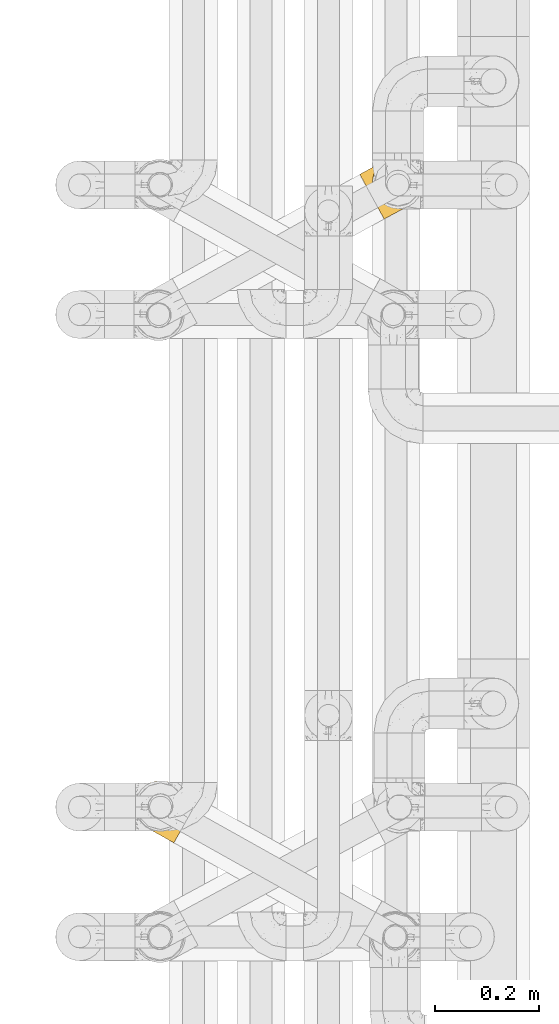
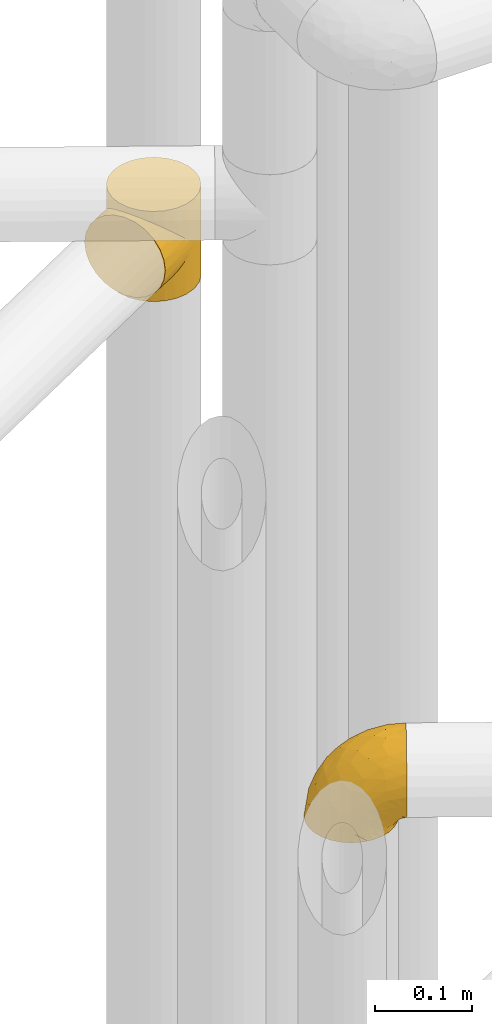
# One storey, part 167 of 827: 2 coverings.
"""IFC2X3 building model written with IfcOpenShell, lengths in millimetres."""

from ifc_helpers import new_model, entity, si_unit, converted_unit, derived_unit, direction, frame, origin, place, context, subcontext, project, spatial, faceted_brep, element, save


model = new_model("IFC2X3")

# Units and contexts
model_context = context("Model", 3, precision=0.01, world=origin(), true_north=direction((6.12303176911189e-17, 1.0)))
body_context = subcontext(model_context, "Body", "Model", "MODEL_VIEW")
ifc_project = project(units=[si_unit("LENGTHUNIT", "METRE", prefix="MILLI"), si_unit("AREAUNIT", "SQUARE_METRE"), si_unit("VOLUMEUNIT", "CUBIC_METRE"), converted_unit("PLANEANGLEUNIT", "DEGREE", entity("IfcRatioMeasure", 0.0174532925199433), si_unit("PLANEANGLEUNIT", "RADIAN"), dimensions=[0, 0, 0, 0, 0, 0, 0]), si_unit("MASSUNIT", "GRAM", prefix="KILO"), derived_unit("MASSDENSITYUNIT", [(si_unit("MASSUNIT", "GRAM", prefix="KILO"), 1), (si_unit("LENGTHUNIT", "METRE"), -3)]), derived_unit("MOMENTOFINERTIAUNIT", [(si_unit("LENGTHUNIT", "METRE"), 4)]), si_unit("TIMEUNIT", "SECOND"), si_unit("FREQUENCYUNIT", "HERTZ"), si_unit("THERMODYNAMICTEMPERATUREUNIT", "DEGREE_CELSIUS"), derived_unit("THERMALTRANSMITTANCEUNIT", [(si_unit("MASSUNIT", "GRAM", prefix="KILO"), 1), (si_unit("THERMODYNAMICTEMPERATUREUNIT", "KELVIN"), -1), (si_unit("TIMEUNIT", "SECOND"), -3)]), derived_unit("VOLUMETRICFLOWRATEUNIT", [(si_unit("LENGTHUNIT", "METRE"), 3), (si_unit("TIMEUNIT", "SECOND"), -1)]), derived_unit("MASSFLOWRATEUNIT", [(si_unit("MASSUNIT", "GRAM", prefix="KILO"), 1), (si_unit("TIMEUNIT", "SECOND"), -1)]), derived_unit("ROTATIONALFREQUENCYUNIT", [(si_unit("TIMEUNIT", "SECOND"), -1)]), si_unit("ELECTRICCURRENTUNIT", "AMPERE"), si_unit("ELECTRICVOLTAGEUNIT", "VOLT"), si_unit("POWERUNIT", "WATT"), si_unit("FORCEUNIT", "NEWTON", prefix="KILO"), si_unit("ILLUMINANCEUNIT", "LUX"), si_unit("LUMINOUSFLUXUNIT", "LUMEN"), si_unit("LUMINOUSINTENSITYUNIT", "CANDELA"), derived_unit("USERDEFINED", [(si_unit("MASSUNIT", "GRAM", prefix="KILO"), -1), (si_unit("LENGTHUNIT", "METRE"), -2), (si_unit("TIMEUNIT", "SECOND"), 3), (si_unit("LUMINOUSFLUXUNIT", "LUMEN"), 1)]), derived_unit("LINEARVELOCITYUNIT", [(si_unit("LENGTHUNIT", "METRE"), 1), (si_unit("TIMEUNIT", "SECOND"), -1)]), si_unit("PRESSUREUNIT", "PASCAL"), derived_unit("USERDEFINED", [(si_unit("LENGTHUNIT", "METRE"), -2), (si_unit("MASSUNIT", "GRAM", prefix="KILO"), 1), (si_unit("TIMEUNIT", "SECOND"), -2)]), derived_unit("LINEARFORCEUNIT", [(si_unit("MASSUNIT", "GRAM", prefix="KILO"), 1), (si_unit("LENGTHUNIT", "METRE"), 1), (si_unit("TIMEUNIT", "SECOND"), -2), (si_unit("LENGTHUNIT", "METRE"), -1)]), derived_unit("PLANARFORCEUNIT", [(si_unit("MASSUNIT", "GRAM", prefix="KILO"), 1), (si_unit("LENGTHUNIT", "METRE"), 1), (si_unit("TIMEUNIT", "SECOND"), -2), (si_unit("LENGTHUNIT", "METRE"), -2)])], contexts=[model_context])

# Site, building, storey
site_placement = place(None, origin())
site = spatial("IfcSite", under=ifc_project, at=site_placement, CompositionType="ELEMENT")
building_placement = place(site_placement, origin())
building = spatial("IfcBuilding", under=site, at=building_placement, CompositionType="ELEMENT")
storey_placement = place(building_placement, frame((0.0, 0.0, 28200.0)))
storey = spatial("IfcBuildingStorey", under=building, at=storey_placement, Name="08", CompositionType="ELEMENT", Elevation=28200.0)

# Coverings
covering_1_placement = place(storey_placement, frame((35659.02, 12938.72, 2043.0)))
element("IfcCovering", 1, at=covering_1_placement, inside=storey, Name=":ADSK_", ObjectType=":ADSK_", PredefinedType="INSULATION", context=body_context, shape_type="Brep", body=[
    faceted_brep([(46.11, 111.63, 50.38), (51.72, 115.18, 0.0), (41.33, 107.65, 0.0), (33.24, 97.68, 0.0), (36.42, 102.26, 37.4), (29.35, 89.87, 25.28), (28.01, 85.97, 0.0), (32.5, 96.44, 31.18), (51.72, 115.18, 57.0), (46.11, 111.63, 63.62), (51.72, 115.18, 114.0), (30.08, 52.85, 8.29), (29.61, 54.55, 0.0), (30.76, 51.55, 0.0), (40.99, 107.32, 43.83), (31.9, 48.55, 7.85), (31.9, 48.55, 0.0), (30.76, 51.55, 114.0), (31.9, 48.55, 106.15), (31.9, 48.55, 114.0), (27.13, 82.55, 19.84), (25.99, 73.3, 0.0), (26.65, 66.92, 0.0), (27.32, 60.54, 0.0), (27.3, 61.56, 10.0), (28.26, 57.15, 8.74), (26.04, 74.54, 15.07), (26.34, 65.98, 11.25), (28.46, 57.54, 0.0), (33.78, 45.96, 0.0), (35.67, 43.36, 0.0), (34.83, 44.29, 8.4), (37.76, 40.02, 8.94), (37.55, 40.76, 0.0), (39.43, 38.16, 0.0), (44.97, 33.14, 12.0), (44.41, 34.12, 0.0), (49.39, 30.08, 0.0), (41.37, 36.58, 10.47), (52.88, 28.13, 16.57), (55.25, 27.46, 0.0), (61.03, 24.87, 22.18), (48.92, 30.64, 14.29), (33.37, 46.42, 8.12), (61.11, 24.85, 0.0), (69.13, 23.17, 28.5), (73.78, 22.83, 0.0), (77.03, 22.84, 35.29), (86.54, 24.15, 0.0), (91.8, 25.72, 49.65), (98.53, 28.74, 0.0), (33.37, 46.42, 105.88), (84.61, 23.73, 42.38), (98.53, 28.74, 57.0), (91.8, 25.72, 64.35), (98.53, 28.74, 114.0), (124.25, 70.62, 114.0), (122.93, 83.38, 114.0), (118.34, 95.36, 114.0), (110.81, 105.75, 114.0), (100.85, 113.84, 114.0), (89.13, 119.07, 114.0), (76.46, 121.09, 114.0), (63.7, 119.76, 114.0), (41.33, 107.65, 114.0), (33.24, 97.68, 114.0), (28.01, 85.97, 114.0), (25.99, 73.3, 114.0), (26.65, 66.92, 114.0), (27.32, 60.54, 114.0), (28.46, 57.54, 114.0), (29.61, 54.55, 114.0), (33.78, 45.96, 114.0), (35.67, 43.36, 114.0), (37.55, 40.76, 114.0), (39.43, 38.16, 114.0), (44.41, 34.12, 114.0), (49.39, 30.08, 114.0), (55.25, 27.46, 114.0), (61.11, 24.85, 114.0), (73.78, 22.83, 114.0), (86.54, 24.15, 114.0), (108.92, 36.27, 114.0), (117.0, 46.23, 114.0), (122.23, 57.95, 114.0), (63.7, 119.76, 0.0), (76.46, 121.09, 0.0), (89.13, 119.07, 0.0), (100.85, 113.84, 0.0), (110.81, 105.75, 0.0), (118.34, 95.36, 0.0), (122.93, 83.38, 0.0), (124.25, 70.62, 0.0), (122.23, 57.95, 0.0), (117.0, 46.23, 0.0), (108.92, 36.27, 0.0), (40.99, 107.32, 70.17), (36.42, 102.26, 76.6), (30.08, 52.85, 105.71), (32.5, 96.44, 82.82), (29.35, 89.87, 88.72), (28.26, 57.15, 105.26), (27.13, 82.55, 94.16), (26.04, 74.54, 98.93), (27.3, 61.56, 104.0), (26.34, 65.98, 102.75), (44.97, 33.14, 102.0), (41.37, 36.58, 103.53), (52.88, 28.13, 97.43), (37.76, 40.02, 105.06), (61.03, 24.87, 91.82), (48.92, 30.64, 99.71), (34.83, 44.29, 105.6), (77.03, 22.84, 78.71), (84.61, 23.73, 71.62), (69.13, 23.17, 85.5), (2.39, 86.56, 44.28), (4.73, 82.24, 32.42), (8.45, 75.38, 22.25), (13.3, 66.43, 14.43), (16.12, 61.21, 11.98), (18.94, 56.0, 9.52), (20.46, 53.2, 9.11), (21.97, 50.41, 8.69), (23.48, 47.61, 8.27), (25.0, 44.82, 7.85), (26.51, 42.02, 8.27), (28.03, 39.22, 8.69), (29.54, 36.43, 9.11), (31.06, 33.63, 9.52), (33.88, 28.42, 11.98), (36.7, 23.21, 14.43), (39.12, 18.73, 18.34), (41.55, 14.25, 22.25), (45.27, 7.39, 32.42), (47.61, 3.07, 44.28), (48.4, 1.6, 57.0), (47.61, 3.07, 69.72), (45.27, 7.39, 81.57), (41.55, 14.25, 91.75), (39.12, 18.73, 95.66), (36.7, 23.21, 99.57), (33.88, 28.42, 102.02), (31.06, 33.63, 104.48), (29.54, 36.43, 104.89), (28.03, 39.22, 105.31), (26.51, 42.02, 105.73), (25.0, 44.82, 106.15), (23.48, 47.61, 105.73), (21.97, 50.41, 105.31), (20.46, 53.2, 104.89), (18.94, 56.0, 104.48), (16.12, 61.21, 102.02), (13.3, 66.43, 99.57), (8.45, 75.38, 91.75), (4.73, 82.24, 81.57), (2.39, 86.56, 69.72), (1.6, 88.04, 57.0)], [[[0, 1, 2]], [[2, 3, 4]], [[5, 3, 6]], [[5, 7, 3]], [[0, 8, 1]], [[8, 9, 10]], [[11, 12, 13]], [[4, 14, 2]], [[7, 4, 3]], [[0, 2, 14]], [[15, 13, 16]], [[17, 18, 19]], [[20, 6, 21]], [[22, 23, 24]], [[15, 11, 13]], [[23, 25, 24]], [[26, 20, 21]], [[27, 21, 22]], [[27, 22, 24]], [[25, 12, 11]], [[25, 23, 28, 12]], [[26, 21, 27]], [[6, 20, 5]], [[29, 30, 31]], [[32, 30, 33, 34]], [[35, 36, 37]], [[38, 36, 35]], [[38, 32, 34]], [[39, 37, 40]], [[41, 39, 40]], [[35, 37, 39, 42]], [[43, 16, 29]], [[40, 44, 41]], [[45, 44, 46]], [[47, 46, 48]], [[49, 48, 50]], [[47, 45, 46]], [[16, 43, 15]], [[51, 19, 18]], [[49, 52, 48]], [[53, 49, 50]], [[54, 53, 55]], [[30, 32, 31]], [[47, 48, 52]], [[36, 38, 34]], [[44, 45, 41]], [[29, 31, 43]], [[56, 57, 58, 59, 60, 61, 62, 63, 10, 64, 65, 66, 67, 68, 69, 70, 71, 17, 19, 72, 73, 74, 75, 76, 77, 78, 79, 80, 81, 55, 82, 83, 84]], [[85, 86, 87, 88, 89, 90, 91, 92, 93, 94, 95, 50, 48, 46, 44, 40, 37, 36, 34, 33, 30, 29, 16, 13, 12, 28, 23, 22, 21, 6, 3, 2, 1]], [[88, 87, 61, 60]], [[58, 90, 89, 59]], [[89, 88, 60, 59]], [[62, 86, 85, 63]], [[1, 8, 10, 63, 85]], [[61, 87, 86, 62]], [[96, 97, 64]], [[18, 17, 98]], [[9, 96, 64]], [[10, 9, 64]], [[65, 99, 100]], [[65, 64, 97]], [[71, 101, 98]], [[65, 100, 66]], [[99, 65, 97]], [[102, 103, 67]], [[104, 68, 105]], [[104, 101, 69]], [[68, 104, 69]], [[103, 105, 67]], [[66, 102, 67]], [[101, 71, 70, 69]], [[68, 67, 105]], [[98, 17, 71]], [[102, 66, 100]], [[106, 76, 107]], [[106, 77, 76]], [[77, 108, 78]], [[109, 75, 74, 73]], [[110, 78, 108]], [[111, 108, 77, 106]], [[19, 51, 72]], [[109, 73, 112]], [[72, 51, 112]], [[76, 75, 107]], [[110, 79, 78]], [[75, 109, 107]], [[113, 114, 81]], [[114, 54, 81]], [[79, 115, 80]], [[115, 79, 110]], [[113, 80, 115]], [[113, 81, 80]], [[54, 55, 81]], [[112, 73, 72]], [[53, 50, 95, 82, 55]], [[82, 95, 94, 83]], [[94, 93, 84, 83]], [[84, 93, 92, 56]], [[56, 92, 91, 57]], [[57, 91, 90, 58]], [[116, 117, 118, 119, 120, 121, 122, 123, 124, 125, 126, 127, 128, 129, 130, 131, 132, 133, 134, 135, 136, 137, 138, 139, 140, 141, 142, 143, 144, 145, 146, 147, 148, 149, 150, 151, 152, 153, 154, 155, 156, 157]], [[25, 123, 122, 121]], [[119, 118, 20]], [[15, 124, 11]], [[27, 120, 119]], [[124, 15, 125]], [[124, 123, 11]], [[120, 24, 121]], [[26, 27, 119]], [[20, 26, 119]], [[24, 120, 27]], [[25, 121, 24]], [[118, 5, 20]], [[7, 5, 117]], [[117, 5, 118]], [[4, 117, 116]], [[0, 116, 157]], [[4, 7, 117]], [[0, 14, 116]], [[8, 0, 157]], [[4, 116, 14]], [[123, 25, 11]], [[9, 157, 156]], [[156, 155, 97]], [[100, 155, 154]], [[100, 99, 155]], [[9, 8, 157]], [[98, 149, 148]], [[97, 96, 156]], [[99, 97, 155]], [[9, 156, 96]], [[18, 148, 147]], [[102, 154, 153]], [[152, 151, 104]], [[18, 98, 148]], [[151, 101, 104]], [[103, 102, 153]], [[105, 153, 152]], [[105, 152, 104]], [[101, 149, 98]], [[101, 151, 150, 149]], [[103, 153, 105]], [[154, 102, 100]], [[146, 145, 112]], [[109, 145, 144, 143]], [[106, 142, 141]], [[107, 142, 106]], [[107, 109, 143]], [[108, 141, 140]], [[110, 108, 140]], [[106, 141, 108, 111]], [[51, 147, 146]], [[140, 139, 110]], [[115, 139, 138]], [[113, 138, 137]], [[54, 137, 136]], [[113, 115, 138]], [[147, 51, 18]], [[54, 114, 137]], [[53, 54, 136]], [[145, 109, 112]], [[113, 137, 114]], [[142, 107, 143]], [[139, 115, 110]], [[146, 112, 51]], [[49, 136, 135]], [[135, 134, 47]], [[45, 134, 133]], [[45, 47, 134]], [[43, 125, 15]], [[49, 53, 136]], [[32, 129, 128, 127]], [[47, 52, 135]], [[49, 135, 52]], [[31, 127, 126]], [[131, 35, 42, 39]], [[125, 43, 126]], [[39, 132, 131]], [[130, 129, 38]], [[43, 31, 126]], [[41, 133, 132]], [[41, 132, 39]], [[35, 130, 38]], [[32, 127, 31]], [[35, 131, 130]], [[129, 32, 38]], [[133, 41, 45]]]),
])
covering_2_placement = place(storey_placement, frame((35225.59, 11735.81, 2246.4)))
element("IfcCovering", 2, at=covering_2_placement, inside=storey, Name=":ADSK_", ObjectType=":ADSK_", PredefinedType="INSULATION", context=body_context, shape_type="Brep", body=[
    faceted_brep([(26.66, 29.42, 1.6), (17.71, 35.84, 1.6), (10.42, 44.09, 1.6), (5.14, 53.75, 1.6), (2.15, 64.35, 1.6), (1.6, 75.34, 1.6), (3.5, 86.18, 1.6), (7.76, 96.32, 1.6), (14.18, 105.26, 1.6), (22.43, 112.55, 1.6), (32.09, 117.83, 1.6), (42.68, 120.82, 1.6), (53.67, 121.38, 1.6), (64.51, 119.47, 1.6), (74.65, 115.21, 1.6), (79.31, 111.87, 1.6), (83.6, 108.79, 1.6), (87.24, 104.67, 1.6), (90.89, 100.55, 1.6), (96.16, 90.88, 1.6), (99.15, 80.29, 1.6), (99.71, 69.3, 1.6), (97.81, 58.46, 1.6), (93.55, 48.32, 1.6), (87.13, 39.37, 1.6), (78.88, 32.08, 1.6), (69.22, 26.81, 1.6), (58.63, 23.82, 1.6), (47.64, 23.26, 1.6), (42.22, 24.21, 1.6), (36.8, 25.16, 1.6), (31.94, 27.2, 1.6), (29.3, 28.31, 1.6), (106.61, 55.59, 11.12), (112.4, 65.94, 16.03), (114.88, 70.38, 19.94), (117.37, 74.82, 23.84), (119.27, 78.23, 28.93), (121.18, 81.64, 34.02), (122.38, 83.78, 39.95), (123.58, 85.92, 45.87), (124.03, 86.72, 52.86), (124.21, 87.05, 55.73), (124.39, 87.38, 58.6), (123.58, 85.92, 71.32), (121.18, 81.64, 83.17), (117.37, 74.82, 93.35), (112.4, 65.94, 101.16), (106.61, 55.59, 106.07), (100.4, 44.49, 107.75), (94.19, 33.39, 106.07), (88.4, 23.04, 101.16), (83.43, 14.16, 93.35), (79.62, 7.34, 83.17), (77.22, 3.06, 71.32), (76.4, 1.6, 58.6), (76.77, 2.25, 52.86), (77.22, 3.06, 45.87), (78.42, 5.2, 39.95), (79.62, 7.34, 34.02), (81.52, 10.75, 28.93), (83.43, 14.16, 23.84), (85.91, 18.6, 19.94), (88.4, 23.04, 16.03), (94.19, 33.39, 11.12), (100.4, 44.49, 9.45), (36.56, 70.4, 81.82), (38.89, 53.31, 84.02), (50.11, 57.76, 93.05), (71.77, 60.5, 102.55), (77.54, 48.23, 104.83), (89.85, 50.39, 105.83), (52.86, 41.3, 91.87), (70.61, 41.75, 101.74), (70.42, 28.97, 97.07), (17.4, 41.01, 38.45), (20.85, 33.97, 22.17), (28.3, 30.22, 42.04), (59.66, 17.07, 77.69), (42.09, 32.24, 75.76), (38.9, 26.67, 62.11), (59.86, 12.12, 66.08), (57.36, 12.25, 54.26), (62.15, 9.57, 55.35), (66.94, 6.89, 56.44), (69.31, 5.56, 56.98), (71.67, 4.24, 57.52), (60.58, 24.87, 87.84), (13.05, 41.95, 19.41), (13.67, 81.91, 48.89), (5.2, 81.14, 26.34), (9.93, 69.76, 44.55), (30.44, 27.31, 23.41), (33.14, 25.8, 28.03), (35.83, 24.29, 32.65), (38.53, 22.78, 37.28), (41.23, 21.27, 41.9), (7.99, 50.47, 20.6), (20.71, 74.86, 63.36), (29.7, 36.89, 62.21), (2.99, 70.9, 19.94), (9.43, 95.38, 13.68), (39.68, 42.44, 80.85), (26.55, 46.45, 66.53), (26.55, 55.8, 71.06), (25.45, 86.42, 63.99), (35.7, 80.68, 75.73), (5.54, 60.58, 26.77), (27.13, 29.16, 4.31), (27.6, 28.9, 7.01), (28.54, 28.37, 12.43), (29.49, 27.84, 17.92), (13.05, 51.66, 43.43), (16.97, 56.67, 56.23), (43.73, 20.71, 54.97), (12.29, 93.78, 34.4), (45.26, 19.02, 44.99), (49.29, 16.76, 48.08), (53.33, 14.5, 51.17), (45.95, 74.95, 87.47), (28.5, 65.39, 74.55), (18.31, 65.77, 60.86), (18.87, 90.1, 49.19), (58.86, 67.73, 95.01), (37.4, 24.8, 10.27), (70.57, 5.87, 48.79), (62.38, 10.7, 45.16), (68.38, 7.92, 44.99), (82.83, 33.96, 6.17), (75.37, 28.61, 7.65), (41.37, 22.75, 21.59), (36.71, 24.48, 19.96), (78.83, 18.94, 21.0), (74.8, 14.44, 27.2), (82.61, 25.77, 14.83), (73.44, 20.48, 19.7), (78.14, 28.13, 10.93), (88.51, 35.06, 9.63), (61.74, 20.18, 19.97), (53.79, 20.29, 21.13), (59.28, 22.09, 14.14), (76.15, 11.72, 30.2), (68.78, 10.84, 36.65), (60.19, 23.55, 8.12), (67.37, 24.74, 9.93), (63.73, 18.02, 24.62), (44.14, 23.12, 11.87), (95.55, 47.2, 7.15), (89.67, 41.06, 5.32), (44.69, 21.08, 26.68), (69.65, 23.68, 13.92), (51.22, 18.4, 30.67), (58.31, 13.02, 42.89), (64.74, 13.43, 34.04), (54.58, 15.93, 36.6), (69.01, 16.32, 26.41), (51.89, 22.62, 10.07), (52.29, 21.65, 15.83), (53.83, 15.13, 41.99), (107.04, 69.44, 14.83), (107.99, 85.96, 26.4), (110.9, 76.23, 21.01), (106.77, 80.0, 19.71), (100.25, 67.84, 5.72), (88.04, 106.16, 21.6), (84.13, 109.22, 19.96), (81.13, 111.59, 28.03), (89.18, 103.6, 11.87), (99.96, 82.95, 9.93), (122.03, 88.71, 58.06), (114.93, 92.67, 56.44), (119.66, 90.03, 57.52), (97.21, 89.68, 8.13), (97.99, 91.23, 14.15), (114.81, 90.91, 44.99), (112.53, 89.04, 36.65), (115.64, 82.3, 30.2), (93.67, 97.23, 10.06), (94.69, 97.42, 15.83), (117.7, 90.12, 48.79), (105.19, 96.82, 42.89), (109.15, 94.72, 45.38), (76.53, 114.16, 12.43), (84.22, 108.48, 10.28), (102.22, 59.55, 9.64), (110.15, 95.35, 55.35), (105.36, 98.03, 54.26), (99.13, 59.13, 6.05), (75.59, 114.69, 7.01), (76.06, 114.42, 9.72), (83.83, 110.08, 32.65), (91.2, 104.21, 26.68), (102.05, 81.56, 13.92), (86.52, 108.57, 37.28), (96.93, 100.02, 30.66), (96.64, 96.87, 21.14), (100.76, 98.48, 36.59), (103.78, 89.56, 24.6), (77.48, 113.63, 17.92), (78.44, 113.09, 23.41), (102.69, 72.0, 10.93), (100.9, 90.13, 19.97), (101.05, 99.53, 41.99), (97.29, 102.55, 48.08), (108.21, 91.12, 34.04), (112.61, 82.03, 27.21), (101.32, 100.29, 51.17), (93.25, 104.8, 44.99), (89.22, 107.06, 41.9), (90.72, 105.31, 55.26), (85.25, 62.01, 104.83), (96.28, 88.69, 87.84), (80.62, 100.46, 75.91), (70.43, 97.31, 80.84), (78.23, 86.67, 91.87), (60.69, 92.34, 83.98), (56.65, 120.3, 19.16), (67.51, 117.84, 22.37), (106.77, 95.97, 66.08), (62.78, 80.4, 93.05), (87.14, 71.31, 101.74), (97.93, 78.16, 97.07), (102.45, 93.56, 77.69), (31.54, 108.37, 44.55), (19.36, 106.45, 26.34), (23.15, 98.82, 48.9), (52.07, 101.54, 70.99), (44.97, 94.82, 74.55), (59.81, 117.19, 37.8), (32.82, 96.46, 63.4), (44.92, 85.34, 81.82), (37.07, 116.91, 26.77), (46.97, 120.11, 20.6), (46.25, 109.22, 56.15), (39.27, 103.29, 60.85), (74.81, 113.4, 42.06), (66.51, 111.08, 57.03), (26.94, 113.68, 19.94), (48.67, 115.14, 43.59), (82.83, 106.21, 62.61), (60.1, 106.4, 66.52)], [[[0, 1, 2, 3, 4, 5, 6, 7, 8, 9, 10, 11, 12, 13, 14, 15, 16, 17, 18, 19, 20, 21, 22, 23, 24, 25, 26, 27, 28, 29, 30, 31, 32]], [[33, 34, 35, 36, 37, 38, 39, 40, 41, 42, 43, 44, 45, 46, 47, 48, 49, 50, 51, 52, 53, 54, 55, 56, 57, 58, 59, 60, 61, 62, 63, 64, 65]], [[66, 67, 68]], [[69, 70, 71]], [[68, 72, 73]], [[73, 72, 74]], [[75, 76, 77]], [[78, 79, 80]], [[51, 50, 73]], [[81, 82, 83, 84, 85, 86, 55]], [[52, 87, 53]], [[74, 52, 51]], [[2, 1, 88]], [[89, 90, 91]], [[77, 92, 93, 94, 95, 96]], [[55, 54, 81]], [[78, 53, 87]], [[5, 90, 6]], [[88, 76, 75]], [[97, 3, 2]], [[89, 91, 98]], [[99, 80, 79]], [[90, 5, 100]], [[74, 87, 52]], [[100, 5, 4]], [[90, 101, 6]], [[79, 102, 103]], [[102, 67, 104]], [[105, 98, 106]], [[107, 4, 3]], [[76, 0, 108, 109, 110, 111, 92]], [[107, 112, 113]], [[114, 77, 96]], [[89, 115, 90]], [[114, 96, 116, 117, 118, 82]], [[75, 97, 88]], [[119, 66, 68]], [[50, 71, 70]], [[100, 91, 90]], [[99, 77, 80]], [[102, 104, 103]], [[97, 107, 3]], [[80, 81, 78]], [[107, 97, 112]], [[68, 73, 70]], [[66, 98, 120]], [[78, 81, 54]], [[114, 81, 80]], [[53, 78, 54]], [[78, 87, 79]], [[102, 87, 72]], [[79, 103, 99]], [[4, 107, 100]], [[91, 100, 107]], [[88, 97, 2]], [[112, 97, 75]], [[99, 112, 75]], [[103, 104, 113]], [[91, 121, 98]], [[89, 105, 122, 115]], [[101, 90, 115]], [[101, 7, 6]], [[88, 1, 76]], [[0, 76, 1]], [[92, 77, 76]], [[73, 74, 51]], [[87, 74, 72]], [[81, 114, 82]], [[77, 114, 80]], [[87, 102, 79]], [[67, 102, 72]], [[68, 67, 72]], [[67, 120, 104]], [[120, 121, 104]], [[104, 121, 113]], [[121, 120, 98]], [[91, 107, 113]], [[91, 113, 121]], [[103, 113, 112]], [[106, 98, 66]], [[105, 89, 98]], [[106, 66, 119]], [[67, 66, 120]], [[68, 69, 123, 119]], [[50, 49, 71]], [[50, 70, 73]], [[112, 99, 103]], [[77, 99, 75]], [[69, 68, 70]], [[29, 124, 110]], [[84, 83, 125]], [[126, 82, 118]], [[59, 58, 127]], [[25, 128, 129]], [[130, 93, 131]], [[132, 62, 133]], [[134, 135, 136]], [[137, 65, 64]], [[64, 134, 137]], [[138, 139, 140]], [[111, 110, 124, 92]], [[134, 136, 137]], [[134, 64, 63]], [[141, 60, 142]], [[125, 58, 57]], [[143, 144, 140]], [[143, 26, 144]], [[127, 83, 82]], [[28, 124, 29]], [[108, 0, 32, 31, 30, 110, 109]], [[30, 29, 110]], [[135, 145, 138]], [[28, 146, 124]], [[57, 56, 55, 86, 85, 84]], [[147, 148, 23]], [[24, 23, 148]], [[25, 144, 26]], [[95, 94, 149]], [[24, 128, 25]], [[150, 138, 144]], [[124, 146, 131]], [[127, 58, 125]], [[151, 149, 139]], [[127, 126, 142]], [[142, 59, 127]], [[152, 142, 126]], [[153, 154, 155]], [[153, 133, 141]], [[146, 28, 27]], [[143, 156, 27]], [[157, 149, 130]], [[61, 133, 62]], [[134, 132, 135]], [[148, 128, 24]], [[65, 137, 147]], [[147, 137, 148]], [[128, 137, 136]], [[137, 128, 148]], [[128, 136, 129]], [[150, 129, 136]], [[25, 129, 144]], [[158, 152, 117]], [[152, 118, 117]], [[153, 142, 152]], [[158, 116, 154]], [[145, 151, 138]], [[153, 152, 158]], [[133, 153, 155]], [[133, 155, 132]], [[153, 141, 142]], [[135, 132, 155]], [[134, 63, 132]], [[145, 135, 155]], [[135, 138, 150]], [[155, 154, 145]], [[151, 154, 96]], [[154, 151, 145]], [[149, 94, 130]], [[82, 126, 127]], [[118, 152, 126]], [[151, 96, 95]], [[139, 149, 157]], [[151, 95, 149]], [[93, 92, 131]], [[130, 146, 156]], [[130, 94, 93]], [[84, 125, 57]], [[127, 125, 83]], [[140, 139, 157]], [[151, 139, 138]], [[140, 157, 143]], [[138, 140, 144]], [[156, 143, 157]], [[27, 26, 143]], [[130, 156, 157]], [[146, 27, 156]], [[132, 63, 62]], [[124, 131, 92]], [[130, 131, 146]], [[129, 150, 144]], [[135, 150, 136]], [[60, 141, 61]], [[60, 59, 142]], [[133, 61, 141]], [[116, 96, 154]], [[153, 158, 154]], [[158, 117, 116]], [[34, 33, 159]], [[160, 161, 162]], [[22, 21, 163]], [[164, 165, 166]], [[19, 18, 167]], [[168, 21, 20]], [[169, 43, 42, 41, 40, 170, 171]], [[172, 173, 168]], [[174, 38, 175]], [[37, 36, 176]], [[177, 164, 178]], [[40, 179, 170]], [[180, 181, 175]], [[17, 182, 183]], [[65, 147, 184]], [[185, 174, 186]], [[23, 22, 187]], [[174, 39, 38]], [[15, 14, 188, 189, 182, 16]], [[179, 40, 39]], [[190, 191, 164]], [[192, 163, 168]], [[33, 184, 159]], [[178, 173, 172]], [[193, 194, 191]], [[18, 183, 167]], [[173, 178, 195]], [[196, 197, 194]], [[198, 199, 183, 182]], [[182, 17, 16]], [[18, 17, 183]], [[200, 159, 184]], [[192, 168, 201]], [[187, 163, 200]], [[202, 203, 180]], [[185, 179, 174]], [[160, 204, 205]], [[206, 181, 180]], [[206, 180, 203]], [[199, 165, 183]], [[165, 164, 167]], [[172, 177, 178]], [[200, 192, 162]], [[205, 161, 160]], [[65, 184, 33]], [[163, 187, 22]], [[175, 204, 180]], [[174, 181, 186]], [[204, 196, 202]], [[197, 160, 162]], [[196, 207, 202]], [[37, 176, 175]], [[196, 204, 160]], [[176, 204, 175]], [[205, 35, 161]], [[34, 159, 161]], [[162, 161, 159]], [[200, 162, 159]], [[197, 162, 201]], [[194, 197, 201]], [[196, 160, 197]], [[191, 195, 178]], [[208, 196, 194]], [[186, 181, 206]], [[175, 181, 174]], [[191, 190, 193]], [[193, 208, 194]], [[195, 194, 201]], [[178, 164, 191]], [[168, 163, 21]], [[166, 165, 199]], [[166, 190, 164]], [[187, 200, 184]], [[184, 147, 187]], [[23, 187, 147]], [[174, 179, 39]], [[170, 179, 185]], [[194, 195, 191]], [[173, 201, 168]], [[201, 173, 195]], [[172, 168, 20]], [[20, 19, 172]], [[177, 172, 19]], [[19, 167, 177]], [[164, 177, 167]], [[35, 205, 36]], [[35, 34, 161]], [[183, 165, 167]], [[162, 192, 201]], [[163, 192, 200]], [[175, 38, 37]], [[36, 205, 176]], [[204, 176, 205]], [[204, 202, 180]], [[207, 196, 208]], [[207, 203, 202]], [[209, 186, 206, 203, 207, 208]], [[48, 210, 71]], [[211, 212, 213]], [[214, 213, 215]], [[216, 217, 13]], [[218, 43, 169, 171, 170, 185, 186]], [[219, 220, 214]], [[47, 46, 221]], [[210, 48, 220]], [[211, 222, 212]], [[222, 45, 44]], [[221, 220, 47]], [[47, 220, 48]], [[221, 211, 214]], [[223, 224, 225]], [[211, 46, 45]], [[226, 227, 215]], [[43, 218, 44]], [[217, 216, 228]], [[227, 229, 230]], [[14, 13, 217]], [[224, 9, 8]], [[10, 231, 11]], [[11, 232, 12]], [[233, 223, 234]], [[235, 208, 193, 190, 166, 199]], [[236, 235, 228]], [[222, 44, 218]], [[106, 230, 229]], [[224, 237, 9]], [[232, 238, 228]], [[9, 237, 10]], [[115, 224, 101]], [[239, 235, 236]], [[232, 11, 231]], [[223, 231, 237]], [[224, 8, 101]], [[223, 229, 234]], [[225, 115, 122, 105]], [[216, 12, 232]], [[209, 235, 239]], [[210, 219, 69]], [[219, 214, 215]], [[230, 119, 219]], [[209, 218, 186]], [[239, 212, 222]], [[239, 222, 218]], [[45, 222, 211]], [[236, 212, 239]], [[213, 212, 240]], [[223, 237, 224]], [[231, 10, 237]], [[238, 232, 231]], [[216, 232, 228]], [[233, 231, 223]], [[236, 238, 240]], [[115, 225, 224]], [[234, 229, 227]], [[8, 7, 101]], [[235, 209, 208]], [[218, 209, 239]], [[217, 228, 235]], [[13, 12, 216]], [[235, 199, 217]], [[217, 199, 198, 182, 189, 188, 14]], [[211, 221, 46]], [[220, 221, 214]], [[71, 210, 69]], [[71, 49, 48]], [[219, 210, 220]], [[226, 215, 213]], [[211, 213, 214]], [[226, 213, 240]], [[215, 227, 230]], [[233, 240, 238]], [[234, 227, 226]], [[233, 234, 226]], [[229, 223, 225]], [[240, 233, 226]], [[233, 238, 231]], [[225, 105, 229]], [[229, 105, 106]], [[106, 119, 230]], [[123, 69, 219, 119]], [[215, 230, 219]], [[238, 236, 228]], [[212, 236, 240]]]),
])

save(model, "model.ifc")
